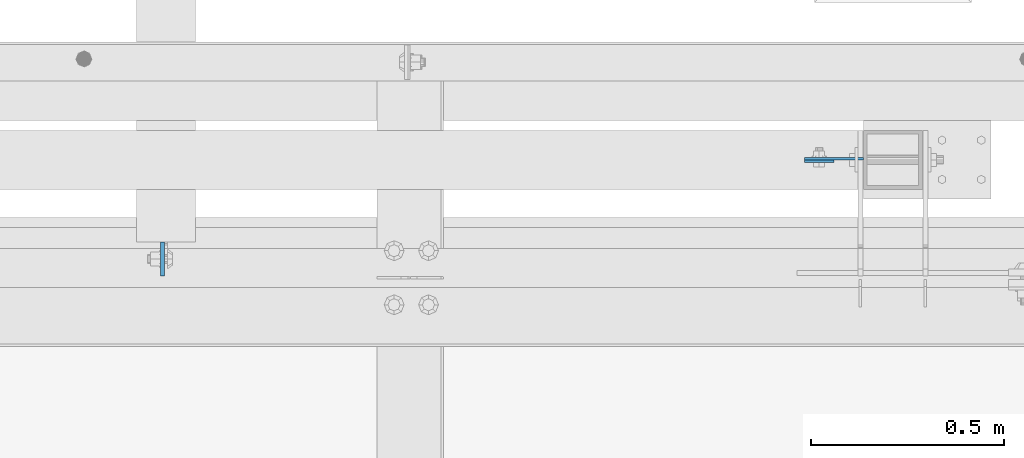
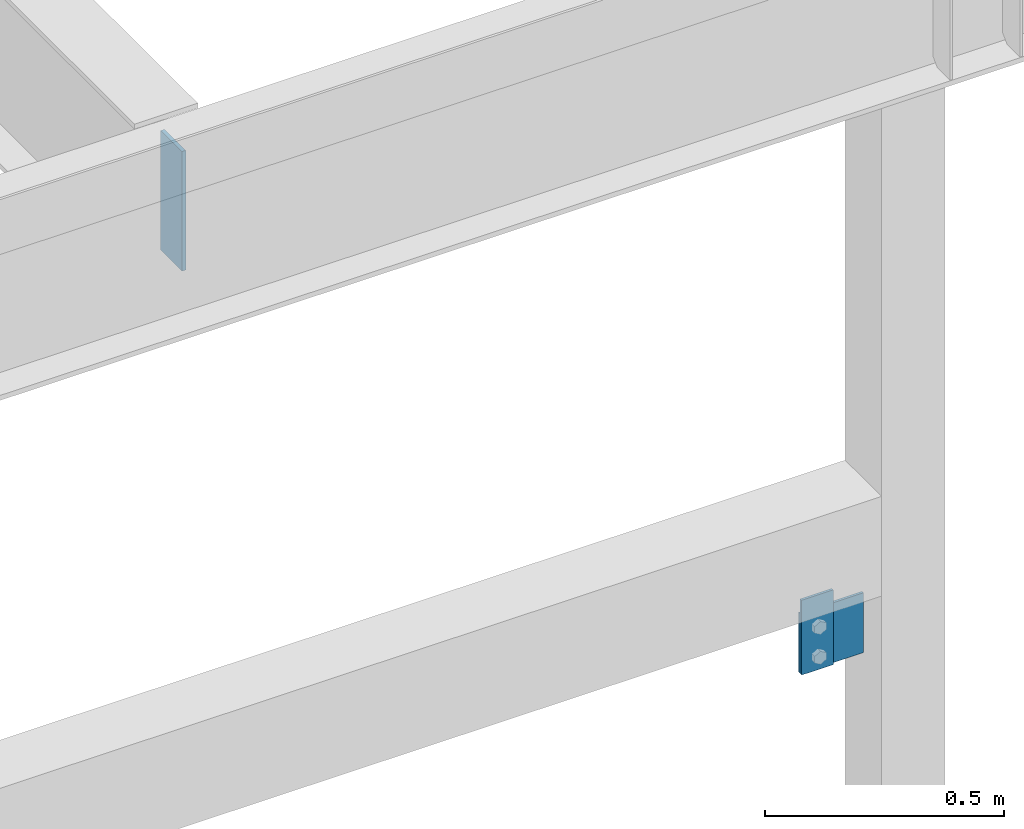
# One storey, part 3501 of 3843: 3 plates, 3 elements without a shape of their own.
"""IFC2X3 building model written with IfcOpenShell, lengths in millimetres."""

from ifc_helpers import new_model, si_unit, frame, origin_with_axes, place, context, subcontext, project, spatial, faceted_brep, material, type_object, element, aggregate, save


model = new_model("IFC2X3")

# Units and contexts
model_context = context("Model", 3, precision=1e-05, world=origin_with_axes())
body_context = subcontext(model_context, "Body", "Model", "MODEL_VIEW")
ifc_project = project(units=[si_unit("LENGTHUNIT", "METRE", prefix="MILLI"), si_unit("AREAUNIT", "SQUARE_METRE"), si_unit("VOLUMEUNIT", "CUBIC_METRE"), si_unit("MASSUNIT", "GRAM", prefix="KILO"), si_unit("TIMEUNIT", "SECOND"), si_unit("PLANEANGLEUNIT", "RADIAN"), si_unit("SOLIDANGLEUNIT", "STERADIAN"), si_unit("THERMODYNAMICTEMPERATUREUNIT", "DEGREE_CELSIUS"), si_unit("LUMINOUSINTENSITYUNIT", "LUMEN")], contexts=[model_context])

# Site, building, storey
site_placement = place(None, origin_with_axes())
site = spatial("IfcSite", under=ifc_project, at=site_placement, CompositionType="ELEMENT")
building_placement = place(site_placement, origin_with_axes())
building = spatial("IfcBuilding", under=site, at=building_placement, Name="Undefined", CompositionType="ELEMENT")
storey_placement = place(building_placement, origin_with_axes())
storey = spatial("IfcBuildingStorey", under=building, at=storey_placement, Name="Undefined", CompositionType="ELEMENT", Elevation=0.0)

# Assembly, plate
assembly_1_placement = place(storey_placement, origin_with_axes())
assembly_1 = element("IfcElementAssembly", 1, at=assembly_1_placement, inside=storey, Name="POST", AssemblyPlace="NOTDEFINED", PredefinedType="RIGID_FRAME")
ifc_material = material(Name="STEEL/A572-50")
plate_type_1 = type_object("IfcPlateType", PredefinedType="NOTDEFINED")
plate_1_placement = place(assembly_1_placement, frame((69519.8, 92522.675, 34455.1), z_axis=(0.0, 0.0, -1.0), x_axis=(-1.0, 0.0, 0.0)))
plate_1 = element("IfcPlate", 2, at=plate_1_placement, type_object=plate_type_1, material=ifc_material, Name="PLATE", context=body_context, shape_type="Brep", body=[
    faceted_brep([(0.0, -3.17499999999927, 0.0), (1.52795109897852e-10, -3.17500000000291, 152.400000000009), (1.52795109897852e-10, 3.17500000000291, 152.400000000009), (0.0, 3.17499999999927, 0.0), (152.399993896484, -3.17500000000291, 152.399993896484), (152.399993896484, 3.17500000000291, 152.399993896484), (152.399998474109, -3.17500000000291, 0.0), (152.399998474109, 3.17500000000291, 0.0)], [[[0, 1, 2, 3]], [[1, 4, 5, 2]], [[4, 6, 7, 5]], [[6, 0, 3, 7]], [[5, 7, 3, 2]], [[6, 4, 1, 0]]]),
])
aggregate(assembly_1, [plate_1])

assembly_2_placement = place(storey_placement, origin_with_axes())
assembly_2 = element("IfcElementAssembly", 3, at=assembly_2_placement, inside=storey, Name="BEAM", AssemblyPlace="NOTDEFINED", PredefinedType="RIGID_FRAME")
plate_type_2 = type_object("IfcPlateType", PredefinedType="NOTDEFINED")
plate_2_placement = place(assembly_2_placement, frame((69367.4000061035, 92516.325, 34302.7000061036), z_axis=(1.0, 0.0, 0.0), x_axis=(0.0, 0.0, 1.0)))
plate_2 = element("IfcPlate", 4, at=plate_2_placement, type_object=plate_type_2, material=ifc_material, Name="PLATE", context=body_context, shape_type="Brep", body=[
    faceted_brep([(0.0, -3.17499999999927, 0.0), (0.0, -3.17499999999927, 76.1999969482422), (0.0, 3.17499999999927, 76.1999969482422), (0.0, 3.17499999999927, 0.0), (190.5, -3.17500000000291, 76.1999969482422), (190.5, 3.17500000000291, 76.1999969482422), (190.5, -3.17500000000291, -3.63797880709171e-12), (190.5, 3.17500000000291, -3.63797880709171e-12)], [[[0, 1, 2, 3]], [[1, 4, 5, 2]], [[4, 6, 7, 5]], [[6, 0, 3, 7]], [[5, 7, 3, 2]], [[6, 4, 1, 0]]]),
])
aggregate(assembly_2, [plate_2])

assembly_3_placement = place(storey_placement, origin_with_axes())
assembly_3 = element("IfcElementAssembly", 5, at=assembly_3_placement, inside=storey, Name="BEAM", AssemblyPlace="NOTDEFINED", PredefinedType="RIGID_FRAME")
plate_type_3 = type_object("IfcPlateType", PredefinedType="NOTDEFINED")
plate_3_placement = place(assembly_3_placement, frame((67707.66875, 92218.66875, 36398.2), z_axis=(0.0, 1.0, 0.0), x_axis=(0.0, 0.0, -1.0)))
plate_3 = element("IfcPlate", 6, at=plate_3_placement, type_object=plate_type_3, material=ifc_material, Name="PLATE", context=body_context, shape_type="Brep", body=[
    faceted_brep([(0.0, -4.76249999999709, 0.0), (0.0, -4.76249999999709, 88.9000015258789), (0.0, 4.76249999999709, 88.9000015258789), (0.0, 4.76249999999709, 0.0), (304.800000000003, -4.76249999999709, 88.8999999999942), (304.800000000003, 4.76249999999709, 88.8999999999942), (304.800000000003, -4.76249999999709, 0.0), (304.800000000003, 4.76249999999709, 0.0)], [[[0, 1, 2, 3]], [[1, 4, 5, 2]], [[4, 6, 7, 5]], [[6, 0, 3, 7]], [[5, 7, 3, 2]], [[6, 4, 1, 0]]]),
])
aggregate(assembly_3, [plate_3])

save(model, "model.ifc")
